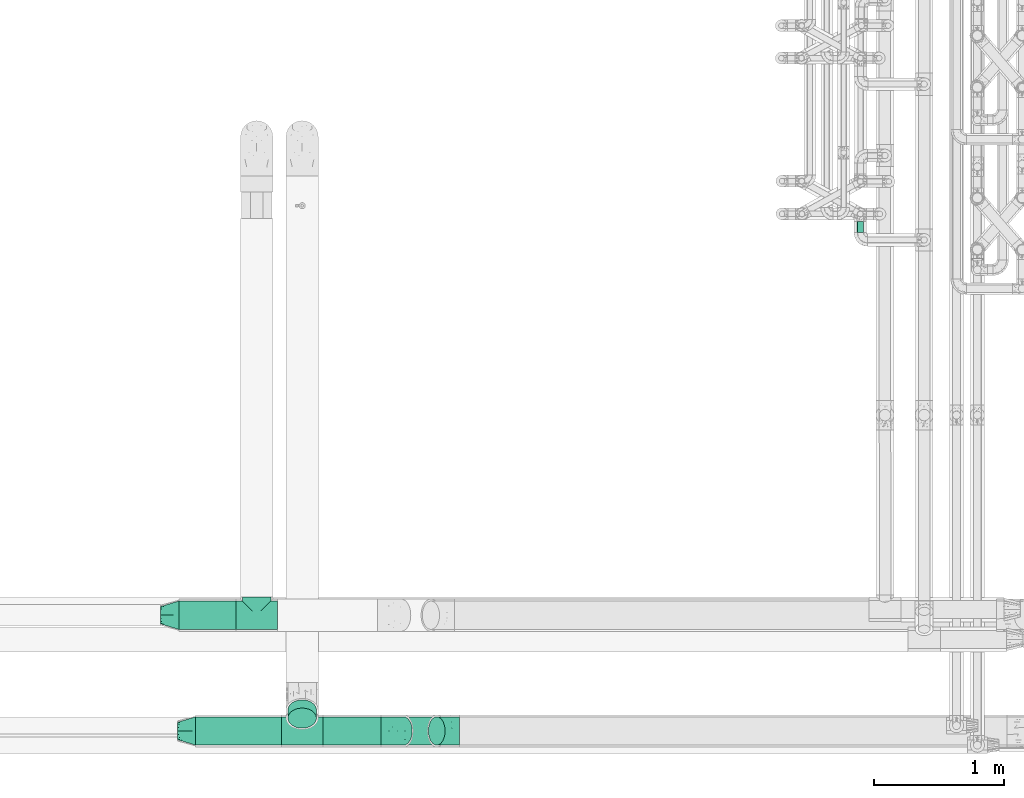
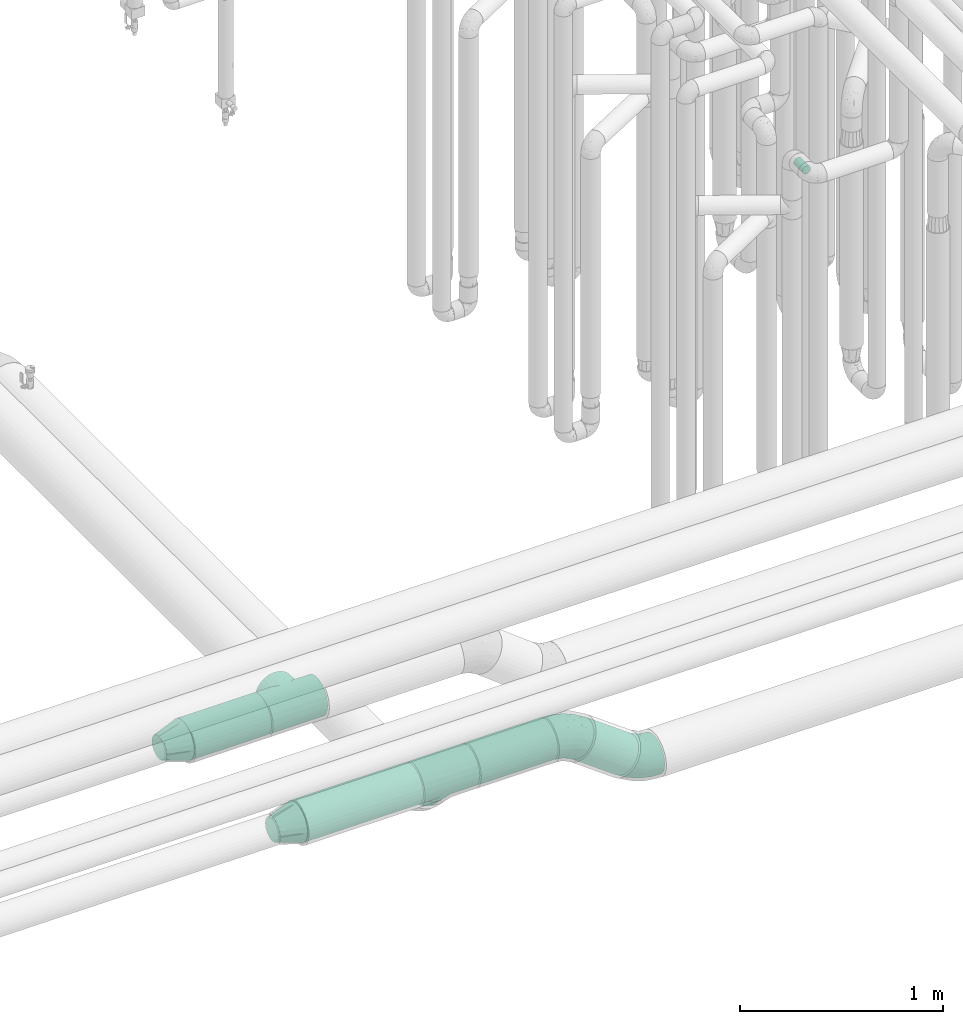
# One storey, part 594 of 827: 6 flow fittings, 6 flow segments.
"""IFC2X3 building model written with IfcOpenShell, lengths in millimetres."""

import ifcopenshell
import ifcopenshell.guid

model = None  # the IFC model being written
_history = None  # IfcOwnerHistory: only IFC2X3 demands one
_inside = {}  # id of a spatial element -> (the spatial element, [elements in it])
_under = {}  # id of a project, library or spatial element -> (it, [spatial elements below it])
_declared = {}  # id of a project -> (the project, [libraries it declares])
_typed = {}  # id of a type object -> (the type object, [elements of that type])
_made_of = {}  # id of a material, layer set ... -> (it, [elements and type objects made of it])


def new_model(schema):
    """Start an empty IFC model of exactly this schema.

    Asked for "IFC4X3", IfcOpenShell would pick the latest addendum, in which some entities
    have other attributes; the version numbers below select the first issue.
    IFC2X3 requires an IfcOwnerHistory on every rooted entity: one is made here for all.
    """
    global model, _history
    if schema == "IFC4X3":
        model = ifcopenshell.file(schema_version=(4, 3, 0, 0))
    else:
        model = ifcopenshell.file(schema=schema)
    _inside.clear()
    _under.clear()
    _declared.clear()
    _typed.clear()
    _made_of.clear()
    _history = None
    if model.schema == "IFC2X3":
        org = make("IfcOrganization", Name="unknown")
        user = make(
            "IfcPersonAndOrganization",
            ThePerson=make("IfcPerson", FamilyName="unknown"),
            TheOrganization=org,
        )
        app = make(
            "IfcApplication",
            ApplicationDeveloper=org,
            Version="unknown",
            ApplicationFullName="unknown",
            ApplicationIdentifier="unknown",
        )
        _history = make(
            "IfcOwnerHistory",
            OwningUser=user,
            OwningApplication=app,
            ChangeAction="ADDED",
            CreationDate=0,
        )
    return model


def make(cls, **values):
    """One entity of the class cls with the attributes given. An attribute that is None is left unset."""
    return model.create_entity(
        cls, **{name: value for name, value in values.items() if value is not None}
    )


def entity(cls, *values):
    """Any entity or typed value of the class cls, its attributes in the order of the schema. None: left unset."""
    e = model.create_entity(cls)
    for i, value in enumerate(values):
        if value is not None:
            e[i] = value
    return e


def rooted(cls, **values):
    """An entity with a GlobalId (a new one), such as an element, a storey or a relation."""
    return make(cls, GlobalId=ifcopenshell.guid.new(), OwnerHistory=_history, **values)


def si_unit(unit_type, name, prefix=None):
    """IfcSIUnit, for example si_unit("LENGTHUNIT", "METRE", prefix="MILLI")."""
    return make("IfcSIUnit", UnitType=unit_type, Prefix=prefix, Name=name)


def converted_unit(unit_type, name, factor, base, dimensions=None, offset=None):
    """IfcConversionBasedUnit, such as the inch: factor (a typed value) times the base unit."""
    return make(
        "IfcConversionBasedUnit"
        if offset is None
        else "IfcConversionBasedUnitWithOffset",
        ConversionOffset=offset,
        Dimensions=None
        if dimensions is None
        else entity("IfcDimensionalExponents", *dimensions),
        UnitType=unit_type,
        Name=name,
        ConversionFactor=make(
            "IfcMeasureWithUnit", ValueComponent=factor, UnitComponent=base
        ),
    )


def derived_unit(unit_type, elements):
    """IfcDerivedUnit: a product of units, each with its exponent."""
    return make(
        "IfcDerivedUnit",
        Elements=[
            make("IfcDerivedUnitElement", Unit=unit, Exponent=power)
            for unit, power in elements
        ],
        UnitType=unit_type,
    )


def assignment(units):
    """IfcUnitAssignment: the units of a project."""
    return None if units is None else make("IfcUnitAssignment", Units=units)


def point(xyz):
    """IfcCartesianPoint."""
    return None if xyz is None else make("IfcCartesianPoint", Coordinates=xyz)


def direction(xyz):
    """IfcDirection."""
    return None if xyz is None else make("IfcDirection", DirectionRatios=xyz)


def frame(location, z_axis=None, x_axis=None):
    """IfcAxis2Placement3D, a coordinate frame: its origin and axes. An axis left out is left unset."""
    return make(
        "IfcAxis2Placement3D",
        Location=point(location),
        Axis=direction(z_axis),
        RefDirection=direction(x_axis),
    )


def frame_2d(location, x_axis=None):
    """IfcAxis2Placement2D, a coordinate frame in the plane: its origin and x axis."""
    return make(
        "IfcAxis2Placement2D", Location=point(location), RefDirection=direction(x_axis)
    )


def origin():
    """The frame at (0, 0, 0) with its axes left unset."""
    return frame((0.0, 0.0, 0.0))


def origin_2d_with_axis():
    """The frame at (0, 0) in the plane with the x axis (1, 0) written out."""
    return frame_2d((0.0, 0.0), x_axis=(1.0, 0.0))


def place(relative_to, where):
    """IfcLocalPlacement: puts the frame where relative to a parent placement (None: the world)."""
    return make(
        "IfcLocalPlacement", PlacementRelTo=relative_to, RelativePlacement=where
    )


def context(
    kind, dimensions, precision=None, world=None, true_north=None, identifier=None
):
    """IfcGeometricRepresentationContext, for example the 3D "Model" context."""
    return make(
        "IfcGeometricRepresentationContext",
        ContextIdentifier=identifier,
        ContextType=kind,
        CoordinateSpaceDimension=dimensions,
        Precision=precision,
        WorldCoordinateSystem=world,
        TrueNorth=true_north,
    )


def subcontext(parent, identifier, kind, view, scale=None):
    """IfcGeometricRepresentationSubContext, for example "Body" below "Model"."""
    return make(
        "IfcGeometricRepresentationSubContext",
        ContextIdentifier=identifier,
        ContextType=kind,
        ParentContext=parent,
        TargetScale=scale,
        TargetView=view,
    )


def project(units=None, contexts=None):
    """IfcProject with its units and contexts."""
    return rooted(
        "IfcProject",
        Name="project",
        RepresentationContexts=contexts,
        UnitsInContext=assignment(units),
    )


def spatial(cls, under=None, at=None, **own):
    """A site, building, storey or space (cls), placed at a placement, below another one or the project."""
    s = rooted(cls, ObjectPlacement=at, **own)
    if under is not None:
        _under.setdefault(under.id(), (under, []))[1].append(s)
    return s


def profile(cls, at=None, kind="AREA", **sizes):
    """A parametric profile (cls). Its sizes go by their IFC names, for example OverallWidth=200.0."""
    return make(cls, ProfileType=kind, Position=at, **sizes)


def circle(**sizes):
    """IfcCircleProfileDef."""
    return profile("IfcCircleProfileDef", **sizes)


def extrude(swept, where, along, depth):
    """IfcExtrudedAreaSolid: the profile swept, set in the frame where, extruded along a direction by depth."""
    return make(
        "IfcExtrudedAreaSolid",
        SweptArea=swept,
        Position=where,
        ExtrudedDirection=direction(along),
        Depth=depth,
    )


def faces_of(points, faces, orient=None, outer=None):
    """IfcFace entities. A face is a list of loops; a loop is a list of indices into points, from 0.

    orient and outer hold one flag for each loop. By default every Orientation is true, the
    first loop of a face is its IfcFaceOuterBound and the others are IfcFaceBound.
    """
    made = []
    for i, loops in enumerate(faces):
        bounds = []
        for j, loop in enumerate(loops):
            is_outer = j == 0 if outer is None else outer[i][j]
            bounds.append(
                make(
                    "IfcFaceOuterBound" if is_outer else "IfcFaceBound",
                    Bound=make("IfcPolyLoop", Polygon=[points[k] for k in loop]),
                    Orientation=True if orient is None else orient[i][j],
                )
            )
        made.append(make("IfcFace", Bounds=bounds))
    return made


def faceted_brep(points, faces, orient=None, outer=None, voids=None):
    """IfcFacetedBrep: a solid bounded by flat faces; with voids (closed shells), ...WithVoids."""
    shared = [point(p) for p in points]
    hull = make("IfcClosedShell", CfsFaces=faces_of(shared, faces, orient, outer))
    if voids is None:
        return make("IfcFacetedBrep", Outer=hull)
    return make(
        "IfcFacetedBrepWithVoids",
        Outer=hull,
        Voids=[
            make(cls, CfsFaces=faces_of(shared, fs, o, b)) for cls, fs, o, b in voids
        ],
    )


def shape(context_of_items, identifier, shape_type, items):
    """IfcShapeRepresentation: the items that make up one representation, for example the "Body"."""
    return make(
        "IfcShapeRepresentation",
        ContextOfItems=context_of_items,
        RepresentationIdentifier=identifier,
        RepresentationType=shape_type,
        Items=items,
    )


def source(mapping_origin, context_of_items, identifier, shape_type, items):
    """IfcRepresentationMap: a shape defined once, which mapped items show again and again."""
    return make(
        "IfcRepresentationMap",
        MappingOrigin=mapping_origin,
        MappedRepresentation=shape(context_of_items, identifier, shape_type, items),
    )


def transform(
    local_origin,
    x_axis=None,
    y_axis=None,
    z_axis=None,
    scale=None,
    scale2=None,
    scale3=None,
    uniform=True,
):
    """IfcCartesianTransformationOperator3D, or its non-uniform kind. x_axis, y_axis, z_axis: its Axis1, 2, 3."""
    if uniform:
        return make(
            "IfcCartesianTransformationOperator3D",
            Axis1=direction(x_axis),
            Axis2=direction(y_axis),
            LocalOrigin=point(local_origin),
            Scale=scale,
            Axis3=direction(z_axis),
        )
    return make(
        "IfcCartesianTransformationOperator3DnonUniform",
        Axis1=direction(x_axis),
        Axis2=direction(y_axis),
        LocalOrigin=point(local_origin),
        Scale=scale,
        Axis3=direction(z_axis),
        Scale2=scale2,
        Scale3=scale3,
    )


def mapped(mapping_source, mapping_target):
    """IfcMappedItem: shows the shape of a source again, moved by a transform."""
    return make(
        "IfcMappedItem", MappingSource=mapping_source, MappingTarget=mapping_target
    )


def material(Name=None, Category=None):
    """IfcMaterial."""
    return make("IfcMaterial", Name=Name, Category=Category)


def made_of(thing, what):
    """Note that an element or type object is made of a material, layer set ...; save() writes the relation."""
    if what is not None:
        _made_of.setdefault(what.id(), (what, []))[1].append(thing)
    return thing


def type_object(cls, material=None, **own):
    """A type object (cls), such as IfcWallType, which elements share."""
    return made_of(rooted(cls, **own), material)


def type_shapes(of_type, sources):
    """Give a type object the sources (RepresentationMaps) that its elements show as mapped items."""
    of_type.RepresentationMaps = sources


def element(
    cls,
    number,
    at=None,
    inside=None,
    cuts=None,
    type_object=None,
    material=None,
    context=None,
    identifier="Body",
    shape_type=None,
    held_by="IfcProductDefinitionShape",
    body=None,
    shapes=None,
    **own,
):
    """One element of the class cls, such as IfcWall. Its Tag is "e" and its number.

    at: its placement. inside: the storey or other place that contains it. cuts: it is an
    opening in that element (IfcRelVoidsElement). A single representation is given by context,
    identifier, shape_type and body (its items); several are given by shapes. held_by: the class
    of the entity that holds the representations. save() writes the other relations.
    """
    e = rooted(cls, Tag="e%d" % number, ObjectPlacement=at, **own)
    if body is not None:
        shapes = [shape(context, identifier, shape_type, body)]
    if shapes is not None:
        e.Representation = make(held_by, Representations=shapes)
    if inside is not None:
        _inside.setdefault(inside.id(), (inside, []))[1].append(e)
    if cuts is not None:
        rooted(
            "IfcRelVoidsElement", RelatingBuildingElement=cuts, RelatedOpeningElement=e
        )
    if type_object is not None:
        _typed.setdefault(type_object.id(), (type_object, []))[1].append(e)
    return made_of(e, material)


def aggregate(whole, parts):
    """IfcRelAggregates: a whole, such as a stair, and the parts it consists of."""
    return rooted("IfcRelAggregates", RelatingObject=whole, RelatedObjects=parts)


def save(model, path):
    """Write the relations noted so far, then the file.

    IfcRelAggregates (storeys below a building ...), IfcRelContainedInSpatialStructure (elements
    in a storey), IfcRelDefinesByType, IfcRelAssociatesMaterial and IfcRelDeclares: one each for
    every whole, place, type object, material and project.
    """
    for whole, parts in _under.values():
        aggregate(whole, parts)
    for where, things in _inside.values():
        rooted(
            "IfcRelContainedInSpatialStructure",
            RelatedElements=things,
            RelatingStructure=where,
        )
    for kind, things in _typed.values():
        rooted("IfcRelDefinesByType", RelatedObjects=things, RelatingType=kind)
    for what, things in _made_of.values():
        rooted("IfcRelAssociatesMaterial", RelatedObjects=things, RelatingMaterial=what)
    for by, libraries in _declared.values():
        rooted("IfcRelDeclares", RelatingContext=by, RelatedDefinitions=libraries)
    model.write(path)


model = new_model("IFC2X3")

# Units and contexts
model_context = context("Model", 3, precision=0.01, world=origin(), true_north=direction((6.12303176911189e-17, 1.0)))
body_context = subcontext(model_context, "Body", "Model", "MODEL_VIEW")
ifc_project = project(units=[si_unit("LENGTHUNIT", "METRE", prefix="MILLI"), si_unit("AREAUNIT", "SQUARE_METRE"), si_unit("VOLUMEUNIT", "CUBIC_METRE"), converted_unit("PLANEANGLEUNIT", "DEGREE", entity("IfcRatioMeasure", 0.0174532925199433), si_unit("PLANEANGLEUNIT", "RADIAN"), dimensions=[0, 0, 0, 0, 0, 0, 0]), si_unit("MASSUNIT", "GRAM", prefix="KILO"), derived_unit("MASSDENSITYUNIT", [(si_unit("MASSUNIT", "GRAM", prefix="KILO"), 1), (si_unit("LENGTHUNIT", "METRE"), -3)]), derived_unit("MOMENTOFINERTIAUNIT", [(si_unit("LENGTHUNIT", "METRE"), 4)]), si_unit("TIMEUNIT", "SECOND"), si_unit("FREQUENCYUNIT", "HERTZ"), si_unit("THERMODYNAMICTEMPERATUREUNIT", "DEGREE_CELSIUS"), derived_unit("THERMALTRANSMITTANCEUNIT", [(si_unit("MASSUNIT", "GRAM", prefix="KILO"), 1), (si_unit("THERMODYNAMICTEMPERATUREUNIT", "KELVIN"), -1), (si_unit("TIMEUNIT", "SECOND"), -3)]), derived_unit("VOLUMETRICFLOWRATEUNIT", [(si_unit("LENGTHUNIT", "METRE"), 3), (si_unit("TIMEUNIT", "SECOND"), -1)]), derived_unit("MASSFLOWRATEUNIT", [(si_unit("MASSUNIT", "GRAM", prefix="KILO"), 1), (si_unit("TIMEUNIT", "SECOND"), -1)]), derived_unit("ROTATIONALFREQUENCYUNIT", [(si_unit("TIMEUNIT", "SECOND"), -1)]), si_unit("ELECTRICCURRENTUNIT", "AMPERE"), si_unit("ELECTRICVOLTAGEUNIT", "VOLT"), si_unit("POWERUNIT", "WATT"), si_unit("FORCEUNIT", "NEWTON", prefix="KILO"), si_unit("ILLUMINANCEUNIT", "LUX"), si_unit("LUMINOUSFLUXUNIT", "LUMEN"), si_unit("LUMINOUSINTENSITYUNIT", "CANDELA"), derived_unit("USERDEFINED", [(si_unit("MASSUNIT", "GRAM", prefix="KILO"), -1), (si_unit("LENGTHUNIT", "METRE"), -2), (si_unit("TIMEUNIT", "SECOND"), 3), (si_unit("LUMINOUSFLUXUNIT", "LUMEN"), 1)]), derived_unit("LINEARVELOCITYUNIT", [(si_unit("LENGTHUNIT", "METRE"), 1), (si_unit("TIMEUNIT", "SECOND"), -1)]), si_unit("PRESSUREUNIT", "PASCAL"), derived_unit("USERDEFINED", [(si_unit("LENGTHUNIT", "METRE"), -2), (si_unit("MASSUNIT", "GRAM", prefix="KILO"), 1), (si_unit("TIMEUNIT", "SECOND"), -2)]), derived_unit("LINEARFORCEUNIT", [(si_unit("MASSUNIT", "GRAM", prefix="KILO"), 1), (si_unit("LENGTHUNIT", "METRE"), 1), (si_unit("TIMEUNIT", "SECOND"), -2), (si_unit("LENGTHUNIT", "METRE"), -1)]), derived_unit("PLANARFORCEUNIT", [(si_unit("MASSUNIT", "GRAM", prefix="KILO"), 1), (si_unit("LENGTHUNIT", "METRE"), 1), (si_unit("TIMEUNIT", "SECOND"), -2), (si_unit("LENGTHUNIT", "METRE"), -2)])], contexts=[model_context])

# Site, building, storey
site_placement = place(None, origin())
site = spatial("IfcSite", under=ifc_project, at=site_placement, CompositionType="ELEMENT")
building_placement = place(site_placement, origin())
building = spatial("IfcBuilding", under=site, at=building_placement, CompositionType="ELEMENT")
storey_placement = place(building_placement, frame((0.0, 0.0, 28200.0)))
storey = spatial("IfcBuildingStorey", under=building, at=storey_placement, Name="08", CompositionType="ELEMENT", Elevation=28200.0)

# Flow segments
pipe_segment_type_1 = type_object("IfcPipeSegmentType", PredefinedType="NOTDEFINED")
flow_segment_1_placement = place(storey_placement, frame((30479.76, 7155.11, 2688.9)))
element("IfcFlowSegment", 1, at=flow_segment_1_placement, inside=storey, type_object=pipe_segment_type_1, context=body_context, shape_type="SweptSolid", body=[
    extrude(circle(Radius=109.5, at=origin_2d_with_axis()), frame((0.0, 111.1, 111.1), z_axis=(1.0, 0.0, 0.0), x_axis=(0.0, 1.0, 0.0)), (0.0, 0.0, 1.0), 440.240643085185),
])
flow_segment_2_placement = place(storey_placement, frame((30610.11, 6263.9, 2688.9)))
element("IfcFlowSegment", 2, at=flow_segment_2_placement, inside=storey, type_object=pipe_segment_type_1, context=body_context, shape_type="SweptSolid", body=[
    extrude(circle(Radius=109.5, at=origin_2d_with_axis()), frame((0.0, 111.1, 111.1), z_axis=(1.0, 0.0, 0.0), x_axis=(0.0, 1.0, 0.0)), (0.0, 0.0, 1.0), 659.891728032664),
])
flow_segment_3_placement = place(storey_placement, frame((31590.0, 6263.9, 2688.9)))
element("IfcFlowSegment", 3, at=flow_segment_3_placement, inside=storey, type_object=pipe_segment_type_1, context=body_context, shape_type="SweptSolid", body=[
    extrude(circle(Radius=109.5, at=origin_2d_with_axis()), frame((0.0, 111.1, 111.1), z_axis=(1.0, 0.0, 0.0), x_axis=(0.0, -1.0, 0.0)), (0.0, 0.0, 1.0), 446.080617390534),
])
flow_segment_4_placement = place(storey_placement, frame((31318.9, 6394.97, 2558.84)))
element("IfcFlowSegment", 4, at=flow_segment_4_placement, inside=storey, type_object=pipe_segment_type_1, context=body_context, shape_type="SweptSolid", body=[
    extrude(circle(Radius=109.5, at=origin_2d_with_axis()), frame((111.1, 79.02, 142.16), z_axis=(0.0, 0.707106781186541, -0.707106781186554), x_axis=(-1.0, 0.0, 0.0)), (0.0, 0.0, 1.0), 89.2893218813854),
])
flow_segment_5_placement = place(storey_placement, frame((32146.69, 6263.9, 2467.48)))
element("IfcFlowSegment", 5, at=flow_segment_5_placement, inside=storey, type_object=pipe_segment_type_1, context=body_context, shape_type="SweptSolid", body=[
    extrude(circle(Radius=109.5, at=origin_2d_with_axis()), frame((319.73, 111.1, 90.08), z_axis=(-0.80811788469918, 0.0, 0.589020784378041), x_axis=(0.0, -1.0, 0.0)), (0.0, 0.0, 1.0), 313.861133125843),
])
pipe_segment_type_2 = type_object("IfcPipeSegmentType", PredefinedType="NOTDEFINED")
flow_segment_6_placement = place(storey_placement, frame((35702.45, 10213.2, 2574.4)))
element("IfcFlowSegment", 6, at=flow_segment_6_placement, inside=storey, type_object=pipe_segment_type_2, context=body_context, shape_type="SweptSolid", body=[
    extrude(circle(Radius=24.0, at=origin_2d_with_axis()), frame((25.6, 0.0, 25.6), z_axis=(0.0, 1.0, 0.0), x_axis=(-1.0, 0.0, 0.0)), (0.0, 0.0, 1.0), 85.9654132835041),
])

# Flow fittings
ifc_material = material()
pipe_fitting_type_1 = type_object("IfcPipeFittingType", Name="ADSK_2", PredefinedType="NOTDEFINED", material=ifc_material)
shared_shape_1 = source(origin(), body_context, "Body", "Brep", [
    faceted_brep([(-160.0, 0.0, -109.5), (-160.0, -28.34, -105.77), (-160.0, -54.75, -94.83), (-160.0, -66.09, -86.13), (-160.0, -77.43, -77.43), (-160.0, -86.13, -66.09), (-160.0, -94.83, -54.75), (-160.0, -100.3, -41.55), (-160.0, -103.03, -34.94), (-160.0, -105.77, -28.34), (-160.0, -106.7, -21.26), (-160.0, -107.63, -14.17), (-160.0, -109.5, 0.0), (-160.0, -107.63, 14.17), (-160.0, -106.7, 21.26), (-160.0, -105.77, 28.34), (-160.0, -103.03, 34.94), (-160.0, -100.3, 41.55), (-160.0, -94.83, 54.75), (-160.0, -86.13, 66.09), (-160.0, -77.43, 77.43), (-160.0, -66.09, 86.13), (-160.0, -54.75, 94.83), (-160.0, -28.34, 105.77), (-160.0, 0.0, 109.5), (-160.0, 28.34, 105.77), (-160.0, 54.75, 94.83), (-160.0, 77.43, 77.43), (-160.0, 94.83, 54.75), (-160.0, 105.77, 28.34), (-160.0, 109.5, 0.0), (-160.0, 105.77, -28.34), (-160.0, 94.83, -54.75), (-160.0, 77.43, -77.43), (-160.0, 54.75, -94.83), (-160.0, 28.34, -105.77), (160.0, 28.34, -105.77), (160.0, 54.75, -94.83), (160.0, 77.43, -77.43), (160.0, 94.83, -54.75), (160.0, 105.77, -28.34), (160.0, 109.5, 0.0), (160.0, 105.77, 28.34), (160.0, 94.83, 54.75), (160.0, 77.43, 77.43), (160.0, 54.75, 94.83), (160.0, 28.34, 105.77), (160.0, 0.0, 109.5), (160.0, -28.34, 105.77), (160.0, -54.75, 94.83), (160.0, -66.09, 86.13), (160.0, -77.43, 77.43), (160.0, -86.13, 66.09), (160.0, -94.83, 54.75), (160.0, -100.3, 41.55), (160.0, -103.03, 34.94), (160.0, -105.77, 28.34), (160.0, -106.7, 21.26), (160.0, -107.63, 14.17), (160.0, -109.5, 0.0), (160.0, -107.63, -14.17), (160.0, -106.7, -21.26), (160.0, -105.77, -28.34), (160.0, -103.03, -34.94), (160.0, -100.3, -41.55), (160.0, -94.83, -54.75), (160.0, -86.13, -66.09), (160.0, -77.43, -77.43), (160.0, -66.09, -86.13), (160.0, -54.75, -94.83), (160.0, -28.34, -105.77), (160.0, 0.0, -109.5), (107.07, -107.07, 22.92), (108.29, -108.29, 11.46), (103.67, -103.67, 33.47), (100.26, -100.26, 44.01), (77.6, -77.6, 77.26), (63.52, -63.52, 89.2), (90.1, -90.1, 62.22), (95.18, -95.18, 53.12), (-100.26, -100.26, 44.01), (-103.67, -103.67, 33.47), (-108.29, -108.29, 11.46), (-107.07, -107.07, 22.92), (-109.5, -109.5, 0.0), (109.5, -109.5, 0.0), (-63.52, -63.52, 89.2), (-77.6, -77.6, 77.26), (-90.1, -90.1, 62.22), (-48.39, -48.39, 98.23), (-95.18, -95.18, 53.12), (48.39, -48.39, 98.23), (16.39, -16.39, 108.27), (32.59, -32.59, 104.54), (0.0, 0.0, 109.5), (-16.39, -16.39, 108.27), (-32.59, -32.59, 104.54), (0.0, 0.0, -109.5), (16.39, -16.39, -108.27), (-108.29, -108.29, -11.46), (108.29, -108.29, -11.46), (-16.39, -16.39, -108.27), (32.59, -32.59, -104.54), (-90.1, -90.1, -62.22), (63.52, -63.52, -89.2), (-103.67, -103.67, -33.47), (-100.26, -100.26, -44.01), (-77.6, -77.6, -77.26), (-63.52, -63.52, -89.2), (-32.59, -32.59, -104.54), (-48.39, -48.39, -98.23), (48.39, -48.39, -98.23), (77.6, -77.6, -77.26), (107.07, -107.07, -22.92), (103.67, -103.67, -33.47), (-95.18, -95.18, -53.12), (90.1, -90.1, -62.22), (100.26, -100.26, -44.01), (-107.07, -107.07, -22.92), (95.18, -95.18, -53.12), (0.0, -140.0, -109.5), (28.34, -140.0, -105.77), (54.75, -140.0, -94.83), (77.43, -140.0, -77.43), (94.83, -140.0, -54.75), (100.3, -140.0, -41.55), (105.77, -140.0, -28.34), (107.63, -140.0, -14.17), (109.5, -140.0, 0.0), (107.63, -140.0, 14.17), (105.77, -140.0, 28.34), (100.3, -140.0, 41.55), (94.83, -140.0, 54.75), (77.43, -140.0, 77.43), (54.75, -140.0, 94.83), (28.34, -140.0, 105.77), (0.0, -140.0, 109.5), (-28.34, -140.0, 105.77), (-54.75, -140.0, 94.83), (-77.43, -140.0, 77.43), (-94.83, -140.0, 54.75), (-100.3, -140.0, 41.55), (-105.77, -140.0, 28.34), (-107.63, -140.0, 14.17), (-109.5, -140.0, 0.0), (-107.63, -140.0, -14.17), (-105.77, -140.0, -28.34), (-100.3, -140.0, -41.55), (-94.83, -140.0, -54.75), (-77.43, -140.0, -77.43), (-54.75, -140.0, -94.83), (-28.34, -140.0, -105.77)], [[[0, 1, 2, 3, 4, 5, 6, 7, 8, 9, 10, 11, 12, 13, 14, 15, 16, 17, 18, 19, 20, 21, 22, 23, 24, 25, 26, 27, 28, 29, 30, 31, 32, 33, 34, 35]], [[36, 37, 38, 39, 40, 41, 42, 43, 44, 45, 46, 47, 48, 49, 50, 51, 52, 53, 54, 55, 56, 57, 58, 59, 60, 61, 62, 63, 64, 65, 66, 67, 68, 69, 70, 71]], [[57, 56, 72, 58]], [[58, 72, 73]], [[59, 58, 73]], [[74, 72, 56]], [[54, 53, 75]], [[52, 51, 76]], [[77, 50, 49]], [[74, 54, 75]], [[78, 52, 76]], [[76, 51, 50]], [[76, 50, 77]], [[53, 78, 79, 75]], [[54, 74, 56, 55]], [[80, 17, 81]], [[12, 82, 13]], [[13, 82, 83]], [[82, 12, 84]], [[59, 73, 85]], [[81, 17, 16, 15]], [[83, 15, 14, 13]], [[78, 53, 52]], [[86, 21, 87]], [[87, 20, 19]], [[88, 19, 18]], [[87, 21, 20]], [[22, 86, 89]], [[88, 18, 80, 90]], [[77, 49, 91]], [[48, 47, 92]], [[93, 91, 48]], [[92, 93, 48]], [[87, 19, 88]], [[92, 47, 94]], [[95, 94, 24]], [[48, 91, 49]], [[28, 27, 44, 43]], [[29, 28, 43, 42]], [[26, 25, 46, 45]], [[27, 26, 45, 44]], [[46, 25, 24, 94, 47]], [[30, 29, 42, 41]], [[80, 18, 17]], [[15, 83, 81]], [[96, 95, 23]], [[96, 23, 89]], [[23, 95, 24]], [[89, 23, 22]], [[86, 22, 21]], [[38, 33, 32, 39]], [[40, 31, 30, 41]], [[40, 39, 32, 31]], [[34, 33, 38, 37]], [[97, 0, 35, 36, 71]], [[98, 71, 70]], [[12, 99, 84]], [[59, 85, 100]], [[98, 97, 71]], [[0, 97, 101]], [[102, 98, 70]], [[103, 6, 5]], [[104, 69, 68]], [[37, 36, 35, 34]], [[105, 7, 106]], [[107, 3, 108]], [[109, 110, 1]], [[101, 109, 1]], [[0, 101, 1]], [[110, 2, 1]], [[102, 70, 111]], [[67, 112, 68]], [[62, 113, 114]], [[104, 68, 112]], [[112, 67, 66]], [[6, 103, 115, 106]], [[66, 65, 116]], [[69, 104, 111]], [[63, 62, 114, 64]], [[117, 64, 114]], [[113, 60, 100]], [[118, 11, 10, 9]], [[65, 117, 119, 116]], [[11, 118, 99]], [[117, 65, 64]], [[113, 62, 61, 60]], [[107, 4, 3]], [[108, 2, 110]], [[108, 3, 2]], [[107, 103, 5]], [[107, 5, 4]], [[112, 66, 116]], [[7, 105, 9, 8]], [[12, 11, 99]], [[105, 118, 9]], [[106, 7, 6]], [[59, 100, 60]], [[69, 111, 70]], [[120, 121, 122, 123, 124, 125, 126, 127, 128, 129, 130, 131, 132, 133, 134, 135, 136, 137, 138, 139, 140, 141, 142, 143, 144, 145, 146, 147, 148, 149, 150, 151]], [[143, 142, 83]], [[144, 82, 84]], [[144, 143, 82]], [[142, 80, 81, 83]], [[139, 138, 86]], [[88, 140, 139]], [[80, 142, 141, 140]], [[89, 138, 137]], [[143, 83, 82]], [[140, 88, 90, 80]], [[86, 87, 139]], [[88, 139, 87]], [[96, 89, 137]], [[136, 94, 95]], [[96, 137, 95]], [[86, 138, 89]], [[75, 132, 131, 130]], [[95, 137, 136]], [[134, 91, 135]], [[135, 92, 136]], [[77, 134, 133]], [[128, 85, 73]], [[133, 132, 78]], [[73, 72, 129]], [[77, 91, 134]], [[93, 92, 135]], [[91, 93, 135]], [[130, 72, 74, 75]], [[72, 130, 129]], [[78, 76, 133]], [[128, 73, 129]], [[132, 75, 79, 78]], [[77, 133, 76]], [[136, 92, 94]], [[127, 126, 113]], [[117, 126, 125, 124]], [[128, 127, 100]], [[126, 117, 114, 113]], [[123, 122, 104]], [[118, 146, 145]], [[128, 100, 85]], [[123, 116, 124]], [[111, 122, 121]], [[124, 116, 119, 117]], [[104, 112, 123]], [[116, 123, 112]], [[102, 111, 121]], [[120, 97, 98]], [[102, 121, 98]], [[104, 122, 111]], [[127, 113, 100]], [[98, 121, 120]], [[150, 110, 151]], [[151, 101, 120]], [[108, 150, 149]], [[144, 84, 99]], [[149, 148, 103]], [[146, 106, 148, 147]], [[99, 118, 145]], [[108, 110, 150]], [[109, 101, 151]], [[110, 109, 151]], [[146, 118, 105, 106]], [[144, 99, 145]], [[103, 107, 149]], [[148, 106, 115, 103]], [[108, 149, 107]], [[120, 101, 97]]]),
])
type_shapes(pipe_fitting_type_1, [shared_shape_1])
for number, where, z_axis, x_axis, name in (
    (7, (31080.0, 7266.2, 2800.0), (2.63361265060741e-05, 0.0, 1.0), (-1.0, 0.0, 2.63361265060741e-05), "ADSK_2"),
    (8, (31430.0, 6375.0, 2800.0), (0.0, 0.707106781186543, 0.707106781186552), (-1.0, 0.0, 0.0), "ADSK_2"),
):
    element("IfcFlowFitting", number, at=place(storey_placement, frame(where, z_axis=z_axis, x_axis=x_axis)), inside=storey, type_object=pipe_fitting_type_1, material=ifc_material, Name=name, ObjectType="ADSK_2", context=body_context, shape_type="MappedRepresentation", body=[
        mapped(shared_shape_1, transform((0.0, 0.0, 0.0), scale=1.0)),
    ])
pipe_fitting_type_2 = type_object("IfcPipeFittingType", Name="ADSK_2", PredefinedType="NOTDEFINED", material=ifc_material)
shared_shape_2 = source(origin(), body_context, "Body", "Brep", [
    faceted_brep([(140.0, -36.24, 54.23), (140.0, -47.02, 47.02), (140.0, -54.23, 36.24), (140.0, -61.44, 25.45), (140.0, -63.97, 12.72), (140.0, -66.5, 0.0), (140.0, -63.97, -12.72), (140.0, -61.44, -25.45), (140.0, -54.23, -36.24), (140.0, -47.02, -47.02), (140.0, -36.24, -54.23), (140.0, -25.45, -61.44), (140.0, -12.72, -63.97), (140.0, 0.0, -66.5), (140.0, 12.72, -63.97), (140.0, 25.45, -61.44), (140.0, 36.24, -54.23), (140.0, 47.02, -47.02), (140.0, 54.23, -36.24), (140.0, 61.44, -25.45), (140.0, 63.97, -12.72), (140.0, 66.5, 0.0), (140.0, 63.97, 12.72), (140.0, 61.44, 25.45), (140.0, 54.23, 36.24), (140.0, 47.02, 47.02), (140.0, 36.24, 54.23), (140.0, 25.45, 61.44), (140.0, 12.72, 63.97), (140.0, 0.0, 66.5), (140.0, -12.72, 63.97), (140.0, -25.45, 61.44), (0.0, 0.0, 109.5), (0.0, 33.84, 104.14), (0.0, 64.36, 88.59), (0.0, 88.59, 64.36), (0.0, 104.14, 33.84), (0.0, 109.5, 0.0), (0.0, 104.14, -33.84), (0.0, 88.59, -64.36), (0.0, 64.36, -88.59), (0.0, 33.84, -104.14), (0.0, 0.0, -109.5), (0.0, -33.84, -104.14), (0.0, -64.36, -88.59), (0.0, -88.59, -64.36), (0.0, -104.14, -33.84), (0.0, -109.5, 0.0), (0.0, -104.14, 33.84), (0.0, -88.59, 64.36), (0.0, -64.36, 88.59), (0.0, -33.84, 104.14)], [[[0, 1, 2, 3, 4, 5, 6, 7, 8, 9, 10, 11, 12, 13, 14, 15, 16, 17, 18, 19, 20, 21, 22, 23, 24, 25, 26, 27, 28, 29, 30, 31]], [[32, 33, 34, 35, 36, 37, 38, 39, 40, 41, 42, 43, 44, 45, 46, 47, 48, 49, 50, 51]], [[37, 20, 38]], [[16, 15, 40, 17]], [[11, 44, 43]], [[14, 13, 42]], [[39, 19, 18, 17]], [[42, 41, 14]], [[17, 40, 39]], [[12, 42, 13]], [[15, 41, 40]], [[10, 9, 44, 11]], [[42, 12, 43]], [[41, 15, 14]], [[8, 7, 45, 9]], [[6, 5, 47]], [[19, 39, 38]], [[46, 7, 6]], [[20, 19, 38]], [[45, 7, 46]], [[6, 47, 46]], [[20, 37, 21]], [[44, 9, 45]], [[12, 11, 43]], [[47, 4, 48]], [[0, 31, 50, 1]], [[27, 34, 33]], [[30, 29, 32]], [[49, 3, 2, 1]], [[32, 51, 30]], [[1, 50, 49]], [[28, 32, 29]], [[31, 51, 50]], [[26, 25, 34, 27]], [[32, 28, 33]], [[51, 31, 30]], [[24, 23, 35, 25]], [[22, 21, 37]], [[3, 49, 48]], [[36, 23, 22]], [[4, 3, 48]], [[35, 23, 36]], [[22, 37, 36]], [[4, 47, 5]], [[34, 25, 35]], [[28, 27, 33]]]),
])
type_shapes(pipe_fitting_type_2, [shared_shape_2])
for number, where, z_axis, x_axis, name in (
    (9, (30610.11, 6375.0, 2800.0), (0.0, 0.0, 1.0), (-1.0, 0.0, 0.0), "ADSK_2"),
    (10, (30479.76, 7266.2, 2800.0), (2.62756642280567e-06, 0.0, 1.0), (-1.0, 0.0, 2.62756642280567e-06), "ADSK_2"),
):
    element("IfcFlowFitting", number, at=place(storey_placement, frame(where, z_axis=z_axis, x_axis=x_axis)), inside=storey, type_object=pipe_fitting_type_2, material=ifc_material, Name=name, ObjectType="ADSK_2", context=body_context, shape_type="MappedRepresentation", body=[
        mapped(shared_shape_2, transform((0.0, 0.0, 0.0), scale=1.0)),
    ])
pipe_fitting_type_3 = type_object("IfcPipeFittingType", Name="ADSK_2", PredefinedType="NOTDEFINED", material=ifc_material)
shared_shape_3 = source(origin(), body_context, "Body", "Brep", [
    faceted_brep([(-97.73, 28.34, -105.77), (-97.73, 0.0, -109.5), (-97.73, -28.34, -105.77), (-97.73, -54.75, -94.83), (-97.73, -77.43, -77.43), (-97.73, -94.83, -54.75), (-97.73, -105.77, -28.34), (-97.73, -109.5, 0.0), (-97.73, -105.77, 28.34), (-97.73, -94.83, 54.75), (-97.73, -77.43, 77.43), (-97.73, -54.75, 94.83), (-97.73, -28.34, 105.77), (-97.73, 0.0, 109.5), (-97.73, 28.34, 105.77), (-97.73, 54.75, 94.83), (-97.73, 77.43, 77.43), (-97.73, 94.83, 54.75), (-97.73, 105.77, 28.34), (-97.73, 109.5, 0.0), (-97.73, 105.77, -28.34), (-97.73, 94.83, -54.75), (-97.73, 77.43, -77.43), (-97.73, 54.75, -94.83), (78.98, 57.56, -109.5), (62.28, 80.47, -105.77), (46.73, 101.81, -94.83), (33.37, 120.14, -77.43), (23.12, 134.2, -54.75), (16.68, 143.04, -28.34), (14.48, 146.05, 0.0), (16.68, 143.04, 28.34), (23.12, 134.2, 54.75), (33.37, 120.14, 77.43), (46.73, 101.81, 94.83), (62.28, 80.47, 105.77), (78.98, 57.56, 109.5), (95.67, 34.66, 105.77), (111.23, 13.32, 94.83), (124.58, -5.01, 77.43), (134.83, -19.07, 54.75), (141.28, -27.91, 28.34), (143.47, -30.92, 0.0), (141.28, -27.91, -28.34), (134.83, -19.07, -54.75), (124.58, -5.01, -77.43), (111.23, 13.32, -94.83), (95.67, 34.66, -105.77), (-33.51, -104.43, 0.0), (-4.51, -94.23, 30.73), (22.67, -69.59, 64.21), (-43.87, -83.93, 65.58), (-39.61, -94.44, 47.42), (29.11, -89.36, 0.0), (88.6, -64.65, 0.0), (59.61, -76.25, 19.08), (-51.56, -39.87, 100.71), (-19.38, -59.78, 85.66), (8.96, -27.5, 100.08), (-25.59, -7.83, 108.3), (-8.48, 26.03, 108.86), (65.15, -1.85, 100.71), (-32.67, 48.47, 101.86), (-24.92, 76.51, 88.16), (72.38, -64.12, 40.08), (84.88, -41.99, 65.58), (-36.84, 94.59, 68.09), (-35.92, 110.26, 43.59), (-38.05, 116.81, 21.68), (58.17, -33.41, 85.78), (14.11, 53.39, 105.53), (39.59, 15.66, 108.36), (-58.03, 113.68, 0.0), (-20.07, 126.05, 0.0), (-2.15, 58.42, -101.86), (-42.85, 34.84, -105.53), (-24.92, 76.51, -88.16), (-39.61, -94.44, -47.42), (-38.05, 116.81, -21.68), (-35.92, 110.26, -43.59), (8.96, -27.5, -100.08), (50.87, -36.9, -85.66), (-27.33, -61.26, -85.78), (-25.95, 98.14, -68.09), (-8.48, 26.03, -108.86), (25.29, 8.74, -108.3), (-41.22, -10.66, -108.36), (-4.51, -94.23, -30.73), (-43.87, -83.93, -65.58), (-51.56, -39.87, -100.71), (22.67, -69.59, -64.21), (59.61, -76.25, -19.08), (72.38, -64.12, -40.08), (65.15, -1.85, -100.71), (84.88, -41.99, -65.58)], [[[0, 1, 2, 3, 4, 5, 6, 7, 8, 9, 10, 11, 12, 13, 14, 15, 16, 17, 18, 19, 20, 21, 22, 23]], [[24, 25, 26, 27, 28, 29, 30, 31, 32, 33, 34, 35, 36, 37, 38, 39, 40, 41, 42, 43, 44, 45, 46, 47]], [[48, 49, 8]], [[48, 8, 7]], [[50, 51, 52]], [[53, 54, 55]], [[56, 57, 58]], [[51, 10, 9]], [[13, 12, 59]], [[12, 11, 56]], [[13, 59, 60]], [[38, 37, 61]], [[52, 51, 9]], [[11, 10, 57]], [[15, 14, 62]], [[16, 15, 63]], [[64, 40, 65]], [[17, 66, 67]], [[14, 13, 60]], [[34, 33, 63]], [[51, 57, 10]], [[67, 68, 18]], [[40, 39, 65]], [[19, 18, 68]], [[18, 17, 67]], [[50, 65, 69]], [[63, 15, 62]], [[49, 53, 55]], [[48, 53, 49]], [[35, 70, 36]], [[38, 69, 39]], [[60, 71, 36]], [[16, 63, 66]], [[60, 59, 71]], [[64, 55, 41]], [[71, 37, 36]], [[41, 55, 54]], [[49, 64, 50]], [[69, 38, 61]], [[57, 69, 58]], [[50, 69, 57]], [[54, 42, 41]], [[49, 55, 64]], [[33, 66, 63]], [[17, 16, 66]], [[72, 68, 73]], [[8, 49, 52]], [[73, 68, 30]], [[58, 61, 71]], [[68, 31, 30]], [[14, 60, 62]], [[67, 66, 32]], [[68, 72, 19]], [[32, 66, 33]], [[31, 68, 67]], [[34, 62, 70]], [[62, 34, 63]], [[32, 31, 67]], [[70, 62, 60]], [[40, 64, 41]], [[58, 71, 59]], [[56, 59, 12]], [[57, 51, 50]], [[8, 52, 9]], [[50, 52, 49]], [[69, 65, 39]], [[64, 65, 50]], [[57, 56, 11]], [[59, 56, 58]], [[71, 61, 37]], [[69, 61, 58]], [[36, 70, 60]], [[34, 70, 35]], [[23, 74, 75]], [[23, 76, 74]], [[77, 6, 5]], [[22, 76, 23]], [[72, 78, 19]], [[78, 20, 19]], [[79, 21, 20]], [[80, 81, 82]], [[83, 22, 21]], [[84, 85, 86]], [[26, 25, 74]], [[1, 0, 75]], [[6, 87, 48]], [[84, 86, 1]], [[48, 7, 6]], [[82, 88, 4]], [[5, 88, 77]], [[80, 86, 85]], [[89, 3, 2]], [[90, 88, 82]], [[5, 4, 88]], [[4, 3, 82]], [[1, 86, 2]], [[28, 27, 83]], [[43, 91, 92]], [[93, 85, 47]], [[78, 72, 73]], [[87, 91, 53]], [[30, 29, 78]], [[94, 81, 45]], [[79, 29, 28]], [[44, 43, 92]], [[46, 45, 81]], [[79, 28, 83]], [[26, 74, 76]], [[94, 92, 90]], [[84, 25, 24]], [[90, 92, 87]], [[79, 83, 21]], [[26, 76, 27]], [[80, 89, 86]], [[84, 24, 85]], [[81, 80, 93]], [[22, 83, 76]], [[24, 47, 85]], [[87, 92, 91]], [[44, 94, 45]], [[47, 46, 93]], [[54, 53, 91]], [[75, 74, 84]], [[42, 54, 43]], [[20, 78, 79]], [[25, 84, 74]], [[48, 87, 53]], [[27, 76, 83]], [[91, 43, 54]], [[82, 3, 89]], [[78, 29, 79]], [[90, 82, 81]], [[78, 73, 30]], [[77, 90, 87]], [[90, 77, 88]], [[6, 77, 87]], [[92, 94, 44]], [[81, 94, 90]], [[86, 89, 2]], [[82, 89, 80]], [[81, 93, 46]], [[85, 93, 80]], [[1, 75, 84]], [[23, 75, 0]]]),
])
type_shapes(pipe_fitting_type_3, [shared_shape_3])
for number, where, z_axis, x_axis, name in (
    (11, (32133.81, 6375.0, 2800.0), (0.0, 1.0, 0.0), (1.0, 0.0, 0.0), "ADSK_2"),
    (12, (32545.4, 6375.0, 2500.0), (0.0, -1.0, 0.0), (0.8081178846992, 0.0, -0.589020784378014), "ADSK_2"),
):
    element("IfcFlowFitting", number, at=place(storey_placement, frame(where, z_axis=z_axis, x_axis=x_axis)), inside=storey, type_object=pipe_fitting_type_3, material=ifc_material, Name=name, ObjectType="ADSK_2", context=body_context, shape_type="MappedRepresentation", body=[
        mapped(shared_shape_3, transform((0.0, 0.0, 0.0), scale=1.0)),
    ])

save(model, "model.ifc")
